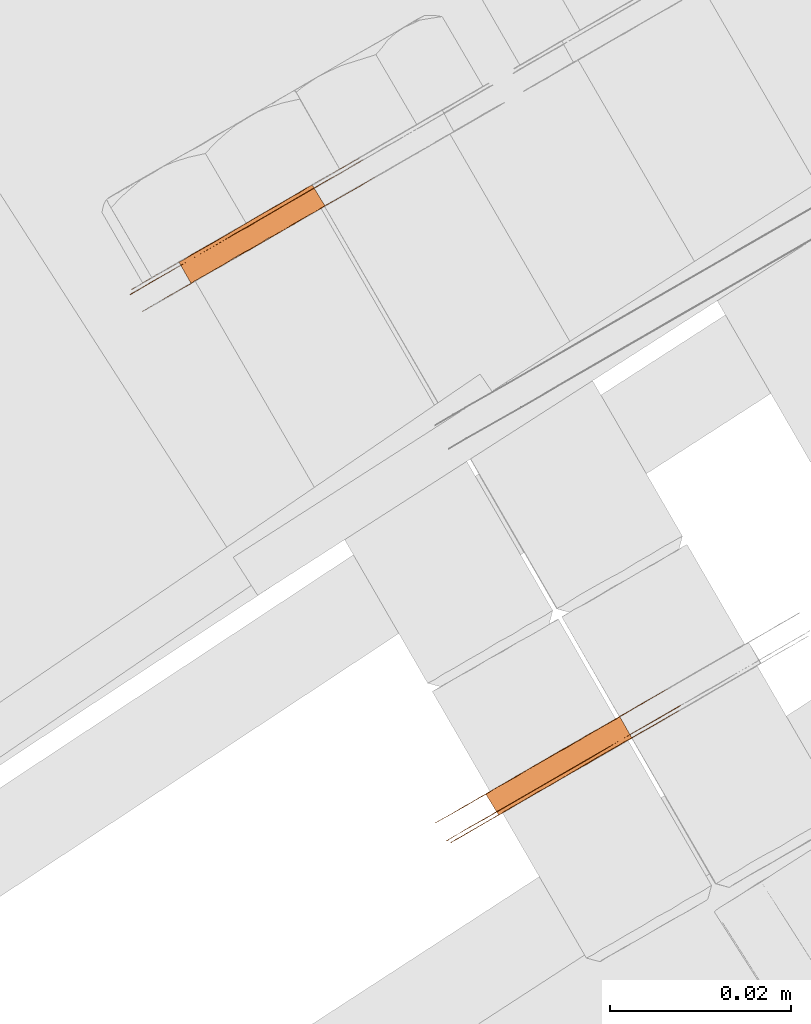
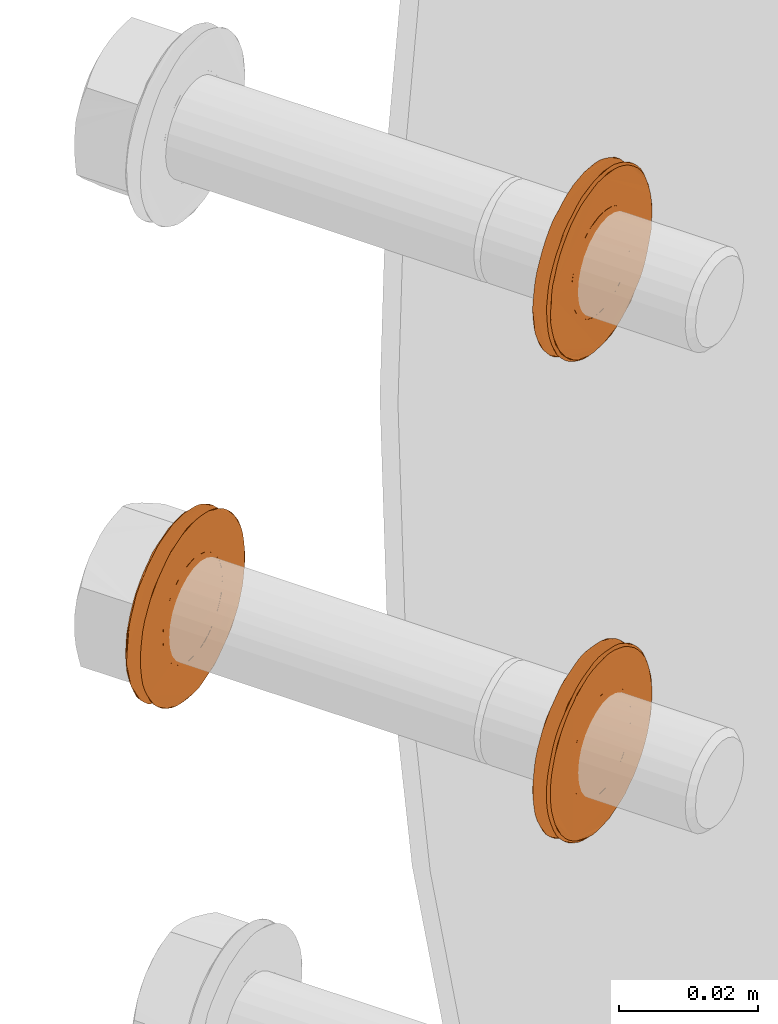
# One storey, part 104 of 126: 3 proxies.
"""IFC2X3 building model written with IfcOpenShell, lengths in millimetres."""

from ifc_helpers import new_model, si_unit, origin, origin_with_axes, place, context, project, spatial, faceted_brep, material, element, save


model = new_model("IFC2X3")

# Units and contexts
context_of_model_1 = context(None, 3, precision=0.1, world=origin())
context_of_model_2 = context(None, 3, precision=0.1, world=origin())
ifc_project = project(units=[si_unit("LENGTHUNIT", "METRE", prefix="MILLI"), si_unit("AREAUNIT", "SQUARE_METRE", prefix="CENTI"), si_unit("VOLUMEUNIT", "CUBIC_METRE", prefix="CENTI"), si_unit("MASSUNIT", "GRAM", prefix="KILO")], contexts=[context_of_model_1, context_of_model_2])

# Site, building, storey
site_placement = place(None, origin_with_axes())
site = spatial("IfcSite", under=ifc_project, at=site_placement, CompositionType="ELEMENT")
building_placement = place(site_placement, origin_with_axes())
building = spatial("IfcBuilding", under=site, at=building_placement, CompositionType="ELEMENT")
storey_placement = place(building_placement, origin_with_axes())
storey = spatial("IfcBuildingStorey", under=building, at=storey_placement, CompositionType="ELEMENT")

# Proxies
ifc_material = material(Name="STAHL")
proxy_1_placement = place(storey_placement, origin_with_axes())
element("IfcBuildingElementProxy", 1, at=proxy_1_placement, inside=storey, material=ifc_material, Name="profile", context=context_of_model_2, shape_type="Brep", body=[
    faceted_brep([(3655.9, 14697.4, 850.3), (3654.6, 14699.7, 850.3), (3654.1, 14699.4, 849.3), (3655.4, 14697.1, 849.3), (3656.3, 14697.6, 851.5), (3655.0, 14699.9, 851.5), (3656.5, 14697.7, 852.6), (3655.2, 14700.1, 852.6), (3656.6, 14697.8, 853.9), (3655.3, 14700.1, 853.9), (3642.0, 14689.3, 852.6), (3640.6, 14691.6, 852.6), (3640.5, 14691.6, 853.9), (3641.9, 14689.3, 853.9), (3642.2, 14689.4, 851.5), (3640.8, 14691.8, 851.5), (3642.6, 14689.7, 850.3), (3641.2, 14692.0, 850.3), (3643.1, 14689.9, 849.3), (3641.7, 14692.3, 849.3), (3643.7, 14690.3, 848.3), (3642.3, 14692.6, 848.3), (3644.4, 14690.7, 847.4), (3643.1, 14693.1, 847.4), (3645.3, 14691.2, 846.7), (3643.9, 14693.6, 846.7), (3646.2, 14691.8, 846.1), (3644.8, 14694.1, 846.1), (3647.2, 14692.3, 845.7), (3645.8, 14694.7, 845.7), (3648.2, 14692.9, 845.4), (3646.9, 14695.3, 845.4), (3649.3, 14693.5, 845.4), (3647.9, 14695.9, 845.4), (3650.3, 14694.1, 845.4), (3648.9, 14696.5, 845.4), (3651.3, 14694.7, 845.7), (3650.0, 14697.1, 845.7), (3652.3, 14695.3, 846.1), (3651.0, 14697.6, 846.1), (3653.2, 14695.8, 846.7), (3651.9, 14698.2, 846.7), (3654.1, 14696.3, 847.4), (3652.7, 14698.6, 847.4), (3654.8, 14696.7, 848.3), (3653.5, 14699.1, 848.3), (3636.1, 14686.4, 853.9), (3636.1, 14686.4, 855.4), (3636.3, 14686.5, 857.0), (3636.7, 14686.7, 858.5), (3637.2, 14687.0, 860.0), (3637.8, 14687.4, 861.4), (3638.5, 14687.8, 862.7), (3639.4, 14688.3, 863.9), (3640.4, 14688.8, 865.0), (3641.4, 14689.5, 866.0), (3642.6, 14690.1, 866.8), (3643.8, 14690.8, 867.6), (3645.0, 14691.5, 868.1), (3646.4, 14692.3, 868.5), (3647.7, 14693.1, 868.8), (3649.1, 14693.9, 868.9), (3650.4, 14694.6, 868.8), (3651.8, 14695.4, 868.5), (3653.1, 14696.2, 868.1), (3654.3, 14696.9, 867.6), (3655.5, 14697.6, 866.8), (3656.7, 14698.3, 866.0), (3657.7, 14698.9, 865.0), (3658.7, 14699.4, 863.9), (3659.6, 14699.9, 862.7), (3660.3, 14700.4, 861.4), (3660.9, 14700.7, 860.0), (3661.4, 14701.0, 858.5), (3661.8, 14701.2, 857.0), (3662.0, 14701.3, 855.4), (3662.0, 14701.4, 853.9), (3662.0, 14701.3, 852.3), (3661.8, 14701.2, 850.7), (3661.4, 14701.0, 849.2), (3660.9, 14700.7, 847.8), (3660.3, 14700.4, 846.4), (3659.6, 14699.9, 845.0), (3658.7, 14699.4, 843.8), (3657.7, 14698.9, 842.7), (3656.7, 14698.3, 841.7), (3655.5, 14700.3, 841.7), (3656.6, 14700.9, 842.7), (3657.6, 14701.4, 843.8), (3658.4, 14701.9, 845.0), (3659.2, 14702.4, 846.4), (3659.8, 14702.7, 847.8), (3660.3, 14703.0, 849.2), (3660.6, 14703.2, 850.7), (3660.8, 14703.3, 852.3), (3660.9, 14703.4, 853.9), (3660.8, 14703.3, 855.4), (3660.6, 14703.2, 857.0), (3660.3, 14703.0, 858.5), (3659.8, 14702.7, 860.0), (3659.2, 14702.4, 861.4), (3658.4, 14701.9, 862.7), (3657.6, 14701.4, 863.9), (3656.6, 14700.9, 865.0), (3655.5, 14700.3, 866.0), (3654.4, 14699.6, 866.8), (3653.2, 14698.9, 867.6), (3651.9, 14698.2, 868.1), (3650.6, 14697.4, 868.5), (3649.3, 14696.6, 868.8), (3647.9, 14695.9, 868.9), (3646.5, 14695.1, 868.8), (3645.2, 14694.3, 868.5), (3643.9, 14693.5, 868.1), (3642.6, 14692.8, 867.6), (3641.4, 14692.1, 866.8), (3640.3, 14691.4, 866.0), (3639.2, 14690.8, 865.0), (3638.2, 14690.3, 863.9), (3637.4, 14689.8, 862.7), (3636.7, 14689.4, 861.4), (3636.0, 14689.0, 860.0), (3635.5, 14688.7, 858.5), (3635.2, 14688.5, 857.0), (3635.0, 14688.4, 855.4), (3634.9, 14688.4, 853.9), (3635.0, 14688.4, 852.3), (3635.2, 14688.5, 850.7), (3635.5, 14688.7, 849.2), (3636.0, 14689.0, 847.8), (3636.7, 14689.4, 846.4), (3637.4, 14689.8, 845.0), (3638.2, 14690.3, 843.8), (3639.2, 14690.8, 842.7), (3640.3, 14691.4, 841.7), (3641.4, 14692.1, 840.9), (3642.6, 14692.8, 840.1), (3643.9, 14693.5, 839.6), (3645.2, 14694.3, 839.2), (3646.5, 14695.1, 838.9), (3647.9, 14695.9, 838.9), (3649.3, 14696.6, 838.9), (3650.6, 14697.4, 839.2), (3651.9, 14698.2, 839.6), (3653.2, 14698.9, 840.1), (3654.4, 14699.6, 840.9), (3655.5, 14697.6, 840.9), (3654.3, 14696.9, 840.1), (3653.1, 14696.2, 839.6), (3651.8, 14695.4, 839.2), (3650.4, 14694.6, 838.9), (3649.1, 14693.9, 838.9), (3647.7, 14693.1, 838.9), (3646.4, 14692.3, 839.2), (3645.0, 14691.5, 839.6), (3643.8, 14690.8, 840.1), (3642.6, 14690.1, 840.9), (3641.4, 14689.5, 841.7), (3640.4, 14688.8, 842.7), (3639.4, 14688.3, 843.8), (3638.5, 14687.8, 845.0), (3637.8, 14687.4, 846.4), (3637.2, 14687.0, 847.8), (3636.7, 14686.7, 849.2), (3636.3, 14686.5, 850.7), (3636.1, 14686.4, 852.3), (3636.6, 14686.2, 853.9), (3636.7, 14686.3, 855.4), (3636.9, 14686.4, 857.0), (3637.3, 14686.6, 858.5), (3637.8, 14686.9, 860.0), (3638.4, 14687.3, 861.4), (3639.2, 14687.7, 862.7), (3640.1, 14688.2, 863.9), (3641.1, 14688.8, 865.0), (3642.2, 14689.4, 865.9), (3643.3, 14690.1, 866.8), (3644.6, 14690.8, 867.4), (3645.9, 14691.6, 867.9), (3647.2, 14692.3, 868.3), (3648.6, 14693.1, 868.4), (3649.9, 14693.9, 868.4), (3651.3, 14694.7, 868.3), (3652.6, 14695.5, 867.9), (3653.9, 14696.2, 867.4), (3655.2, 14696.9, 866.8), (3656.3, 14697.6, 865.9), (3657.4, 14698.2, 865.0), (3658.4, 14698.8, 863.9), (3659.3, 14699.3, 862.7), (3660.1, 14699.8, 861.4), (3660.7, 14700.1, 860.0), (3661.2, 14700.4, 858.5), (3661.6, 14700.6, 857.0), (3661.8, 14700.8, 855.4), (3661.9, 14700.8, 853.9), (3661.8, 14700.8, 852.3), (3661.6, 14700.6, 850.7), (3661.2, 14700.4, 849.2), (3660.7, 14700.1, 847.7), (3660.1, 14699.8, 846.3), (3659.3, 14699.3, 845.0), (3658.4, 14698.8, 843.8), (3657.4, 14698.2, 842.7), (3656.3, 14697.6, 841.8), (3655.2, 14696.9, 841.0), (3653.9, 14696.2, 840.3), (3652.6, 14695.5, 839.8), (3651.3, 14694.7, 839.4), (3649.9, 14693.9, 839.3), (3648.6, 14693.1, 839.3), (3647.2, 14692.3, 839.4), (3645.9, 14691.6, 839.8), (3644.6, 14690.8, 840.3), (3643.3, 14690.1, 841.0), (3642.2, 14689.4, 841.8), (3641.1, 14688.8, 842.7), (3640.1, 14688.2, 843.8), (3639.2, 14687.7, 845.0), (3638.4, 14687.3, 846.3), (3637.8, 14686.9, 847.7), (3637.3, 14686.6, 849.2), (3636.9, 14686.4, 850.7), (3636.7, 14686.3, 852.3), (3654.8, 14696.7, 859.4), (3655.4, 14697.1, 858.4), (3655.9, 14697.4, 857.4), (3656.3, 14697.6, 856.2), (3656.5, 14697.7, 855.1), (3642.0, 14689.3, 855.1), (3642.2, 14689.4, 856.2), (3642.6, 14689.7, 857.4), (3643.1, 14689.9, 858.4), (3643.7, 14690.3, 859.4), (3644.4, 14690.7, 860.3), (3645.3, 14691.2, 861.0), (3646.2, 14691.8, 861.6), (3647.2, 14692.3, 862.0), (3648.2, 14692.9, 862.3), (3649.3, 14693.5, 862.4), (3650.3, 14694.1, 862.3), (3651.3, 14694.7, 862.0), (3652.3, 14695.3, 861.6), (3653.2, 14695.8, 861.0), (3654.1, 14696.3, 860.3), (3640.6, 14691.6, 855.1), (3655.2, 14700.1, 855.1), (3655.0, 14699.9, 856.2), (3654.6, 14699.7, 857.4), (3654.1, 14699.4, 858.4), (3653.5, 14699.1, 859.4), (3652.7, 14698.6, 860.3), (3651.9, 14698.2, 861.0), (3651.0, 14697.6, 861.6), (3650.0, 14697.1, 862.0), (3648.9, 14696.5, 862.3), (3647.9, 14695.9, 862.4), (3646.9, 14695.3, 862.3), (3645.8, 14694.7, 862.0), (3644.8, 14694.1, 861.6), (3643.9, 14693.6, 861.0), (3643.1, 14693.1, 860.3), (3642.3, 14692.6, 859.4), (3641.7, 14692.3, 858.4), (3641.2, 14692.0, 857.4), (3640.8, 14691.8, 856.2)], [[[0, 1, 2, 3]], [[4, 5, 1, 0]], [[6, 7, 5, 4]], [[6, 8, 9, 7]], [[10, 11, 12, 13]], [[14, 15, 11, 10]], [[16, 17, 15, 14]], [[18, 19, 17, 16]], [[20, 21, 19, 18]], [[22, 23, 21, 20]], [[24, 25, 23, 22]], [[26, 27, 25, 24]], [[28, 29, 27, 26]], [[30, 31, 29, 28]], [[32, 33, 31, 30]], [[34, 35, 33, 32]], [[36, 37, 35, 34]], [[38, 39, 37, 36]], [[40, 41, 39, 38]], [[42, 43, 41, 40]], [[44, 45, 43, 42]], [[3, 2, 45, 44]], [[46, 47, 48, 49, 50, 51, 52, 53, 54, 55, 56, 57, 58, 59, 60, 61, 62, 63, 64, 65, 66, 67, 68, 69, 70, 71, 72, 73, 74, 75, 76, 77, 78, 79, 80, 81, 82, 83, 84, 85, 86, 87, 88, 89, 90, 91, 92, 93, 94, 95, 96, 97, 98, 99, 100, 101, 102, 103, 104, 105, 106, 107, 108, 109, 110, 111, 112, 113, 114, 115, 116, 117, 118, 119, 120, 121, 122, 123, 124, 125, 126, 127, 128, 129, 130, 131, 132, 133, 134, 135, 136, 137, 138, 139, 140, 141, 142, 143, 144, 145, 86, 85, 146, 147, 148, 149, 150, 151, 152, 153, 154, 155, 156, 157, 158, 159, 160, 161, 162, 163, 164, 165]], [[166, 167, 168, 169, 170, 171, 172, 173, 174, 175, 176, 177, 178, 179, 180, 181, 182, 183, 184, 185, 186, 187, 68, 67, 66, 65, 64, 63, 62, 61, 60, 59, 58, 57, 56, 55, 54, 53, 52, 51, 50, 49, 48, 47, 46, 165, 164, 163, 162, 161, 160, 159, 158, 157, 156, 155, 154, 153, 152, 151, 150, 149, 148, 147, 146, 85, 84, 83, 82, 81, 80, 79, 78, 77, 76, 75, 74, 73, 72, 71, 70, 69, 68, 187, 188, 189, 190, 191, 192, 193, 194, 195, 196, 197, 198, 199, 200, 201, 202, 203, 204, 205, 206, 207, 208, 209, 210, 211, 212, 213, 214, 215, 216, 217, 218, 219, 220, 221, 222, 223]], [[166, 223, 222, 221, 220, 219, 218, 217, 216, 215, 214, 213, 212, 211, 210, 209, 208, 207, 206, 205, 204, 203, 202, 201, 200, 199, 198, 197, 196, 195, 194, 193, 192, 191, 190, 189, 188, 224, 225, 226, 227, 228, 8, 6, 4, 0, 3, 44, 42, 40, 38, 36, 34, 32, 30, 28, 26, 24, 22, 20, 18, 16, 14, 10, 13, 229, 230, 231, 232, 233, 234, 235, 236, 237, 238, 239, 240, 241, 242, 243, 244, 224, 188, 187, 186, 185, 184, 183, 182, 181, 180, 179, 178, 177, 176, 175, 174, 173, 172, 171, 170, 169, 168, 167]], [[229, 13, 12, 245]], [[228, 246, 9, 8]], [[228, 227, 247, 246]], [[227, 226, 248, 247]], [[226, 225, 249, 248]], [[225, 224, 250, 249]], [[224, 244, 251, 250]], [[244, 243, 252, 251]], [[243, 242, 253, 252]], [[242, 241, 254, 253]], [[241, 240, 255, 254]], [[240, 239, 256, 255]], [[239, 238, 257, 256]], [[238, 237, 258, 257]], [[237, 236, 259, 258]], [[236, 235, 260, 259]], [[235, 234, 261, 260]], [[234, 233, 262, 261]], [[233, 232, 263, 262]], [[232, 231, 264, 263]], [[231, 230, 265, 264]], [[230, 229, 245, 265]], [[125, 124, 123, 122, 121, 120, 119, 118, 117, 116, 115, 114, 113, 112, 111, 110, 109, 108, 107, 106, 105, 104, 103, 102, 101, 250, 251, 252, 253, 254, 255, 256, 257, 258, 259, 260, 261, 262, 263, 264, 265, 245, 12, 11, 15, 17, 19, 21, 23, 25, 27, 29, 31, 33, 35, 37, 39, 41, 43, 45, 2, 1, 5, 7, 9, 246, 247, 248, 249, 250, 101, 100, 99, 98, 97, 96, 95, 94, 93, 92, 91, 90, 89, 88, 87, 86, 145, 144, 143, 142, 141, 140, 139, 138, 137, 136, 135, 134, 133, 132, 131, 130, 129, 128, 127, 126]]]),
])
proxy_2_placement = place(storey_placement, origin_with_axes())
element("IfcBuildingElementProxy", 2, at=proxy_2_placement, inside=storey, material=ifc_material, Name="profile", context=context_of_model_2, shape_type="Brep", body=[
    faceted_brep([(3621.4, 14758.7, 853.9), (3622.8, 14756.4, 853.9), (3622.7, 14756.4, 855.1), (3621.3, 14758.7, 855.1), (3606.7, 14750.2, 853.9), (3606.8, 14750.3, 855.1), (3608.1, 14747.9, 855.1), (3608.0, 14747.9, 853.9), (3607.0, 14750.4, 856.2), (3608.3, 14748.1, 856.2), (3607.4, 14750.6, 857.4), (3608.7, 14748.3, 857.4), (3607.9, 14750.9, 858.4), (3609.2, 14748.6, 858.4), (3608.5, 14751.3, 859.4), (3609.8, 14748.9, 859.4), (3609.2, 14751.7, 860.3), (3610.6, 14749.4, 860.3), (3610.1, 14752.2, 861.0), (3611.4, 14749.8, 861.0), (3611.0, 14752.7, 861.6), (3612.3, 14750.4, 861.6), (3612.0, 14753.3, 862.0), (3613.3, 14751.0, 862.0), (3613.0, 14753.9, 862.3), (3614.4, 14751.5, 862.3), (3614.1, 14754.5, 862.4), (3615.4, 14752.1, 862.4), (3615.1, 14755.1, 862.3), (3616.4, 14752.8, 862.3), (3616.1, 14755.7, 862.0), (3617.5, 14753.3, 862.0), (3617.1, 14756.3, 861.6), (3618.5, 14753.9, 861.6), (3618.0, 14756.8, 861.0), (3619.4, 14754.4, 861.0), (3618.9, 14757.3, 860.3), (3620.2, 14754.9, 860.3), (3619.6, 14757.7, 859.4), (3621.0, 14755.4, 859.4), (3620.2, 14758.1, 858.4), (3621.6, 14755.7, 858.4), (3620.7, 14758.4, 857.4), (3622.1, 14756.0, 857.4), (3621.1, 14758.6, 856.2), (3622.5, 14756.2, 856.2), (3602.4, 14744.6, 853.9), (3602.5, 14744.7, 855.4), (3602.7, 14744.8, 857.0), (3603.0, 14745.0, 858.5), (3603.5, 14745.3, 860.0), (3604.2, 14745.7, 861.4), (3604.9, 14746.1, 862.7), (3605.7, 14746.6, 863.9), (3606.7, 14747.1, 865.0), (3607.8, 14747.7, 866.0), (3608.9, 14748.4, 866.8), (3610.1, 14749.1, 867.6), (3611.4, 14749.8, 868.1), (3612.7, 14750.6, 868.5), (3614.0, 14751.4, 868.8), (3615.4, 14752.1, 868.9), (3616.8, 14752.9, 868.8), (3618.1, 14753.7, 868.5), (3619.4, 14754.5, 868.1), (3620.7, 14755.2, 867.6), (3620.7, 14757.9, 866.8), (3619.5, 14757.2, 867.6), (3618.3, 14756.5, 868.1), (3617.0, 14755.7, 868.5), (3615.6, 14754.9, 868.8), (3614.3, 14754.1, 868.9), (3612.9, 14753.4, 868.8), (3611.6, 14752.6, 868.5), (3610.2, 14751.8, 868.1), (3609.0, 14751.1, 867.6), (3607.8, 14750.4, 866.8), (3606.6, 14749.7, 866.0), (3605.6, 14749.1, 865.0), (3604.6, 14748.6, 863.9), (3603.7, 14748.1, 862.7), (3603.0, 14747.6, 861.4), (3602.4, 14747.3, 860.0), (3601.9, 14747.0, 858.5), (3601.5, 14746.8, 857.0), (3601.3, 14746.7, 855.4), (3601.3, 14746.6, 853.9), (3601.3, 14746.7, 852.3), (3601.5, 14746.8, 850.7), (3601.9, 14747.0, 849.2), (3602.4, 14747.3, 847.8), (3603.0, 14747.6, 846.4), (3603.7, 14748.1, 845.0), (3604.6, 14748.6, 843.8), (3605.6, 14749.1, 842.7), (3606.6, 14749.7, 841.7), (3607.8, 14750.4, 840.9), (3609.0, 14751.1, 840.1), (3610.2, 14751.8, 839.6), (3611.6, 14752.6, 839.2), (3612.9, 14753.4, 838.9), (3614.3, 14754.1, 838.9), (3615.6, 14754.9, 838.9), (3617.0, 14755.7, 839.2), (3618.3, 14756.5, 839.6), (3619.5, 14757.2, 840.1), (3620.7, 14757.9, 840.9), (3621.9, 14758.5, 841.7), (3622.9, 14759.2, 842.7), (3623.9, 14759.7, 843.8), (3624.8, 14760.2, 845.0), (3625.5, 14760.6, 846.4), (3626.1, 14761.0, 847.8), (3626.6, 14761.3, 849.2), (3627.0, 14761.5, 850.7), (3627.2, 14761.6, 852.3), (3627.2, 14761.6, 853.9), (3627.2, 14761.6, 855.4), (3627.0, 14761.5, 857.0), (3626.6, 14761.3, 858.5), (3626.1, 14761.0, 860.0), (3625.5, 14760.6, 861.4), (3624.8, 14760.2, 862.7), (3623.9, 14759.7, 863.9), (3622.9, 14759.2, 865.0), (3621.9, 14758.5, 866.0), (3621.9, 14755.9, 866.8), (3623.0, 14756.6, 866.0), (3624.1, 14757.2, 865.0), (3625.1, 14757.7, 863.9), (3625.9, 14758.2, 862.7), (3626.7, 14758.6, 861.4), (3627.3, 14759.0, 860.0), (3627.8, 14759.3, 858.5), (3628.1, 14759.5, 857.0), (3628.3, 14759.6, 855.4), (3628.4, 14759.6, 853.9), (3628.3, 14759.6, 852.3), (3628.1, 14759.5, 850.7), (3627.8, 14759.3, 849.2), (3627.3, 14759.0, 847.8), (3626.7, 14758.6, 846.4), (3625.9, 14758.2, 845.0), (3625.1, 14757.7, 843.8), (3624.1, 14757.2, 842.7), (3623.0, 14756.6, 841.7), (3621.9, 14755.9, 840.9), (3620.7, 14755.2, 840.1), (3619.4, 14754.5, 839.6), (3618.1, 14753.7, 839.2), (3616.8, 14752.9, 838.9), (3615.4, 14752.1, 838.9), (3614.0, 14751.4, 838.9), (3612.7, 14750.6, 839.2), (3611.4, 14749.8, 839.6), (3610.1, 14749.1, 840.1), (3608.9, 14748.4, 840.9), (3607.8, 14747.7, 841.7), (3606.7, 14747.1, 842.7), (3605.7, 14746.6, 843.8), (3604.9, 14746.1, 845.0), (3604.2, 14745.7, 846.4), (3603.5, 14745.3, 847.8), (3603.0, 14745.0, 849.2), (3602.7, 14744.8, 850.7), (3602.5, 14744.7, 852.3), (3623.2, 14759.8, 843.8), (3624.1, 14760.3, 845.0), (3624.9, 14760.7, 846.3), (3625.5, 14761.1, 847.7), (3626.0, 14761.4, 849.2), (3626.4, 14761.6, 850.7), (3626.6, 14761.7, 852.3), (3626.7, 14761.8, 853.9), (3626.6, 14761.7, 855.4), (3626.4, 14761.6, 857.0), (3626.0, 14761.4, 858.5), (3625.5, 14761.1, 860.0), (3624.9, 14760.7, 861.4), (3624.1, 14760.3, 862.7), (3623.2, 14759.8, 863.9), (3622.2, 14759.2, 865.0), (3621.1, 14758.6, 865.9), (3620.0, 14757.9, 866.8), (3618.7, 14757.2, 867.4), (3617.4, 14756.4, 867.9), (3616.1, 14755.7, 868.3), (3614.7, 14754.9, 868.4), (3613.4, 14754.1, 868.4), (3612.0, 14753.3, 868.3), (3610.7, 14752.5, 867.9), (3609.4, 14751.8, 867.4), (3608.1, 14751.1, 866.8), (3607.0, 14750.4, 865.9), (3605.9, 14749.8, 865.0), (3604.9, 14749.2, 863.9), (3604.0, 14748.7, 862.7), (3603.2, 14748.2, 861.4), (3602.6, 14747.9, 860.0), (3602.1, 14747.6, 858.5), (3601.7, 14747.4, 857.0), (3601.5, 14747.2, 855.4), (3601.4, 14747.2, 853.9), (3601.5, 14747.2, 852.3), (3601.7, 14747.4, 850.7), (3602.1, 14747.6, 849.2), (3602.6, 14747.9, 847.7), (3603.2, 14748.2, 846.3), (3604.0, 14748.7, 845.0), (3604.9, 14749.2, 843.8), (3605.9, 14749.8, 842.7), (3607.0, 14750.4, 841.8), (3608.1, 14751.1, 841.0), (3609.4, 14751.8, 840.3), (3610.7, 14752.5, 839.8), (3612.0, 14753.3, 839.4), (3613.4, 14754.1, 839.3), (3614.7, 14754.9, 839.3), (3616.1, 14755.7, 839.4), (3617.4, 14756.4, 839.8), (3618.7, 14757.2, 840.3), (3620.0, 14757.9, 841.0), (3621.1, 14758.6, 841.8), (3622.2, 14759.2, 842.7), (3619.6, 14757.7, 848.3), (3620.2, 14758.1, 849.3), (3620.7, 14758.4, 850.3), (3621.1, 14758.6, 851.5), (3621.3, 14758.7, 852.6), (3606.8, 14750.3, 852.6), (3607.0, 14750.4, 851.5), (3607.4, 14750.6, 850.3), (3607.9, 14750.9, 849.3), (3608.5, 14751.3, 848.3), (3609.2, 14751.7, 847.4), (3610.1, 14752.2, 846.7), (3611.0, 14752.7, 846.1), (3612.0, 14753.3, 845.7), (3613.0, 14753.9, 845.4), (3614.1, 14754.5, 845.4), (3615.1, 14755.1, 845.4), (3616.1, 14755.7, 845.7), (3617.1, 14756.3, 846.1), (3618.0, 14756.8, 846.7), (3618.9, 14757.3, 847.4), (3608.7, 14748.3, 850.3), (3609.2, 14748.6, 849.3), (3608.3, 14748.1, 851.5), (3622.7, 14756.4, 852.6), (3608.1, 14747.9, 852.6), (3622.5, 14756.2, 851.5), (3622.1, 14756.0, 850.3), (3621.6, 14755.7, 849.3), (3621.0, 14755.4, 848.3), (3620.2, 14754.9, 847.4), (3619.4, 14754.4, 846.7), (3618.5, 14753.9, 846.1), (3617.5, 14753.3, 845.7), (3616.4, 14752.8, 845.4), (3615.4, 14752.1, 845.4), (3614.4, 14751.5, 845.4), (3613.3, 14751.0, 845.7), (3612.3, 14750.4, 846.1), (3611.4, 14749.8, 846.7), (3610.6, 14749.4, 847.4), (3609.8, 14748.9, 848.3)], [[[0, 1, 2, 3]], [[4, 5, 6, 7]], [[5, 8, 9, 6]], [[8, 10, 11, 9]], [[10, 12, 13, 11]], [[12, 14, 15, 13]], [[14, 16, 17, 15]], [[16, 18, 19, 17]], [[18, 20, 21, 19]], [[20, 22, 23, 21]], [[22, 24, 25, 23]], [[24, 26, 27, 25]], [[26, 28, 29, 27]], [[28, 30, 31, 29]], [[30, 32, 33, 31]], [[32, 34, 35, 33]], [[34, 36, 37, 35]], [[36, 38, 39, 37]], [[38, 40, 41, 39]], [[40, 42, 43, 41]], [[42, 44, 45, 43]], [[44, 3, 2, 45]], [[46, 47, 48, 49, 50, 51, 52, 53, 54, 55, 56, 57, 58, 59, 60, 61, 62, 63, 64, 65, 66, 67, 68, 69, 70, 71, 72, 73, 74, 75, 76, 77, 78, 79, 80, 81, 82, 83, 84, 85, 86, 87, 88, 89, 90, 91, 92, 93, 94, 95, 96, 97, 98, 99, 100, 101, 102, 103, 104, 105, 106, 107, 108, 109, 110, 111, 112, 113, 114, 115, 116, 117, 118, 119, 120, 121, 122, 123, 124, 125, 66, 65, 126, 127, 128, 129, 130, 131, 132, 133, 134, 135, 136, 137, 138, 139, 140, 141, 142, 143, 144, 145, 146, 147, 148, 149, 150, 151, 152, 153, 154, 155, 156, 157, 158, 159, 160, 161, 162, 163, 164, 165]], [[86, 85, 84, 83, 82, 81, 80, 79, 78, 77, 76, 75, 74, 73, 72, 71, 70, 69, 68, 67, 66, 125, 124, 123, 122, 121, 120, 119, 118, 117, 116, 115, 114, 113, 112, 111, 110, 109, 166, 167, 168, 169, 170, 171, 172, 173, 174, 175, 176, 177, 178, 179, 180, 181, 182, 183, 184, 185, 186, 187, 188, 189, 190, 191, 192, 193, 194, 195, 196, 197, 198, 199, 200, 201, 202, 203, 204, 205, 206, 207, 208, 209, 210, 211, 212, 213, 214, 215, 216, 217, 218, 219, 220, 221, 222, 223, 166, 109, 108, 107, 106, 105, 104, 103, 102, 101, 100, 99, 98, 97, 96, 95, 94, 93, 92, 91, 90, 89, 88, 87]], [[202, 201, 200, 199, 198, 197, 196, 195, 194, 193, 192, 191, 190, 189, 188, 187, 186, 185, 184, 183, 182, 181, 180, 179, 178, 177, 176, 175, 174, 173, 172, 171, 170, 169, 168, 167, 166, 224, 225, 226, 227, 228, 0, 3, 44, 42, 40, 38, 36, 34, 32, 30, 28, 26, 24, 22, 20, 18, 16, 14, 12, 10, 8, 5, 4, 229, 230, 231, 232, 233, 234, 235, 236, 237, 238, 239, 240, 241, 242, 243, 244, 224, 166, 223, 222, 221, 220, 219, 218, 217, 216, 215, 214, 213, 212, 211, 210, 209, 208, 207, 206, 205, 204, 203]], [[231, 245, 246, 232]], [[230, 247, 245, 231]], [[0, 228, 248, 1]], [[229, 249, 247, 230]], [[4, 7, 249, 229]], [[227, 250, 248, 228]], [[226, 251, 250, 227]], [[225, 252, 251, 226]], [[224, 253, 252, 225]], [[244, 254, 253, 224]], [[243, 255, 254, 244]], [[242, 256, 255, 243]], [[241, 257, 256, 242]], [[240, 258, 257, 241]], [[239, 259, 258, 240]], [[238, 260, 259, 239]], [[237, 261, 260, 238]], [[236, 262, 261, 237]], [[235, 263, 262, 236]], [[234, 264, 263, 235]], [[233, 265, 264, 234]], [[232, 246, 265, 233]], [[46, 165, 164, 163, 162, 161, 160, 159, 158, 157, 156, 155, 154, 153, 152, 151, 150, 149, 148, 147, 146, 145, 144, 143, 142, 253, 254, 255, 256, 257, 258, 259, 260, 261, 262, 263, 264, 265, 246, 245, 247, 249, 7, 6, 9, 11, 13, 15, 17, 19, 21, 23, 25, 27, 29, 31, 33, 35, 37, 39, 41, 43, 45, 2, 1, 248, 250, 251, 252, 253, 142, 141, 140, 139, 138, 137, 136, 135, 134, 133, 132, 131, 130, 129, 128, 127, 126, 65, 64, 63, 62, 61, 60, 59, 58, 57, 56, 55, 54, 53, 52, 51, 50, 49, 48, 47]]]),
])
proxy_3_placement = place(storey_placement, origin_with_axes())
element("IfcBuildingElementProxy", 3, at=proxy_3_placement, inside=storey, material=ifc_material, Name="profile", context=context_of_model_2, shape_type="Brep", body=[
    faceted_brep([(3655.2, 14697.0, 933.2), (3653.9, 14699.3, 933.2), (3653.2, 14698.9, 932.2), (3654.5, 14696.6, 932.2), (3655.8, 14697.3, 934.2), (3654.4, 14699.6, 934.2), (3656.2, 14697.5, 935.3), (3654.8, 14699.9, 935.3), (3641.9, 14689.3, 938.6), (3640.6, 14691.6, 938.6), (3640.7, 14691.7, 939.8), (3642.0, 14689.3, 939.8), (3656.5, 14697.7, 936.5), (3655.1, 14700.0, 936.5), (3641.9, 14689.3, 937.4), (3640.6, 14691.6, 937.4), (3642.1, 14689.4, 936.2), (3640.7, 14691.7, 936.2), (3642.4, 14689.6, 935.0), (3641.1, 14691.9, 935.0), (3642.9, 14689.8, 933.9), (3641.5, 14692.2, 933.9), (3643.4, 14690.2, 932.9), (3642.1, 14692.5, 932.9), (3644.1, 14690.6, 932.0), (3642.8, 14692.9, 932.0), (3644.9, 14691.0, 931.3), (3643.6, 14693.4, 931.3), (3645.8, 14691.5, 930.6), (3644.5, 14693.9, 930.6), (3646.8, 14692.1, 930.1), (3645.5, 14694.4, 930.1), (3647.8, 14692.7, 929.8), (3646.5, 14695.0, 929.8), (3648.9, 14693.3, 929.7), (3647.5, 14695.6, 929.7), (3649.9, 14693.9, 929.7), (3648.6, 14696.2, 929.7), (3650.9, 14694.5, 929.9), (3649.6, 14696.8, 929.9), (3651.9, 14695.1, 930.2), (3650.6, 14697.4, 930.2), (3652.9, 14695.6, 930.8), (3651.5, 14698.0, 930.8), (3653.8, 14696.1, 931.4), (3652.4, 14698.5, 931.4), (3636.1, 14686.4, 938.0), (3636.1, 14686.4, 939.5), (3636.3, 14686.5, 941.1), (3636.6, 14686.7, 942.6), (3637.1, 14687.0, 944.1), (3637.7, 14687.3, 945.5), (3638.4, 14687.7, 946.8), (3639.3, 14688.2, 948.0), (3640.2, 14688.8, 949.2), (3641.3, 14689.4, 950.2), (3642.4, 14690.0, 951.0), (3643.6, 14690.7, 951.8), (3644.9, 14691.5, 952.4), (3646.2, 14692.2, 952.8), (3647.5, 14693.0, 953.0), (3648.9, 14693.8, 953.1), (3650.2, 14694.6, 953.1), (3651.6, 14695.3, 952.9), (3652.9, 14696.1, 952.5), (3654.2, 14696.8, 951.9), (3655.4, 14697.5, 951.2), (3656.5, 14698.2, 950.4), (3657.6, 14698.8, 949.4), (3658.6, 14699.4, 948.3), (3659.5, 14699.9, 947.1), (3660.2, 14700.3, 945.8), (3660.8, 14700.7, 944.4), (3661.4, 14701.0, 943.0), (3661.7, 14701.2, 941.5), (3662.0, 14701.3, 939.9), (3662.0, 14701.4, 938.3), (3662.0, 14701.3, 936.8), (3661.8, 14701.2, 935.2), (3661.5, 14701.0, 933.7), (3661.0, 14700.8, 932.2), (3660.4, 14700.4, 930.8), (3659.7, 14700.0, 929.5), (3658.8, 14699.5, 928.3), (3657.9, 14699.0, 927.1), (3656.8, 14698.4, 926.1), (3655.7, 14697.7, 925.3), (3654.5, 14697.0, 924.5), (3653.3, 14699.0, 924.5), (3654.5, 14699.7, 925.3), (3655.7, 14700.3, 926.1), (3656.7, 14700.9, 927.1), (3657.7, 14701.5, 928.3), (3658.5, 14702.0, 929.5), (3659.2, 14702.4, 930.8), (3659.8, 14702.7, 932.2), (3660.3, 14703.0, 933.7), (3660.6, 14703.2, 935.2), (3660.8, 14703.3, 936.8), (3660.9, 14703.4, 938.3), (3660.8, 14703.3, 939.9), (3660.6, 14703.2, 941.5), (3660.2, 14703.0, 943.0), (3659.7, 14702.7, 944.4), (3659.1, 14702.3, 945.8), (3658.3, 14701.9, 947.1), (3657.4, 14701.4, 948.3), (3656.5, 14700.8, 949.4), (3655.4, 14700.2, 950.4), (3654.2, 14699.5, 951.2), (3653.0, 14698.8, 951.9), (3651.8, 14698.1, 952.5), (3650.4, 14697.3, 952.9), (3649.1, 14696.5, 953.1), (3647.7, 14695.8, 953.1), (3646.4, 14695.0, 953.0), (3645.0, 14694.2, 952.8), (3643.7, 14693.4, 952.4), (3642.5, 14692.7, 951.8), (3641.3, 14692.0, 951.0), (3640.1, 14691.4, 950.2), (3639.1, 14690.8, 949.2), (3638.1, 14690.2, 948.0), (3637.3, 14689.7, 946.8), (3636.6, 14689.3, 945.5), (3636.0, 14689.0, 944.1), (3635.5, 14688.7, 942.6), (3635.2, 14688.5, 941.1), (3635.0, 14688.4, 939.5), (3634.9, 14688.4, 938.0), (3635.0, 14688.4, 936.4), (3635.2, 14688.5, 934.8), (3635.6, 14688.8, 933.3), (3636.1, 14689.0, 931.9), (3636.7, 14689.4, 930.5), (3637.5, 14689.8, 929.2), (3638.4, 14690.3, 928.0), (3639.3, 14690.9, 926.9), (3640.4, 14691.5, 925.9), (3641.6, 14692.2, 925.1), (3642.8, 14692.9, 924.4), (3644.1, 14693.6, 923.8), (3645.4, 14694.4, 923.4), (3646.7, 14695.2, 923.2), (3648.1, 14696.0, 923.1), (3649.4, 14696.7, 923.3), (3650.8, 14697.5, 923.5), (3652.1, 14698.3, 923.9), (3653.2, 14696.3, 923.9), (3651.9, 14695.5, 923.5), (3650.6, 14694.7, 923.3), (3649.2, 14694.0, 923.1), (3647.9, 14693.2, 923.2), (3646.5, 14692.4, 923.4), (3645.2, 14691.6, 923.8), (3643.9, 14690.9, 924.4), (3642.7, 14690.2, 925.1), (3641.6, 14689.5, 925.9), (3640.5, 14688.9, 926.9), (3639.5, 14688.4, 928.0), (3638.6, 14687.9, 929.2), (3637.9, 14687.4, 930.5), (3637.3, 14687.1, 931.9), (3636.8, 14686.8, 933.3), (3636.4, 14686.5, 934.8), (3636.2, 14686.4, 936.4), (3636.6, 14686.2, 937.9), (3636.7, 14686.2, 939.4), (3636.9, 14686.4, 941.0), (3637.2, 14686.6, 942.5), (3637.7, 14686.8, 944.0), (3638.3, 14687.2, 945.4), (3639.0, 14687.6, 946.7), (3639.9, 14688.1, 948.0), (3640.9, 14688.7, 949.1), (3641.9, 14689.3, 950.1), (3643.1, 14690.0, 950.9), (3644.3, 14690.7, 951.6), (3645.6, 14691.4, 952.1), (3647.0, 14692.2, 952.5), (3648.3, 14693.0, 952.7), (3649.7, 14693.8, 952.7), (3651.0, 14694.6, 952.6), (3652.4, 14695.3, 952.3), (3653.7, 14696.1, 951.8), (3654.9, 14696.8, 951.2), (3656.1, 14697.5, 950.4), (3657.2, 14698.1, 949.5), (3658.3, 14698.7, 948.4), (3659.2, 14699.2, 947.2), (3660.0, 14699.7, 945.9), (3660.6, 14700.1, 944.5), (3661.1, 14700.4, 943.1), (3661.5, 14700.6, 941.6), (3661.8, 14700.8, 940.0), (3661.9, 14700.8, 938.4), (3661.8, 14700.8, 936.9), (3661.7, 14700.7, 935.3), (3661.3, 14700.5, 933.8), (3660.8, 14700.2, 932.3), (3660.2, 14699.8, 930.9), (3659.5, 14699.4, 929.5), (3658.6, 14698.9, 928.3), (3657.6, 14698.4, 927.2), (3656.6, 14697.7, 926.2), (3655.4, 14697.1, 925.4), (3654.2, 14696.4, 924.7), (3652.9, 14695.6, 924.2), (3651.6, 14694.8, 923.8), (3650.2, 14694.1, 923.6), (3648.8, 14693.3, 923.6), (3647.5, 14692.5, 923.7), (3646.1, 14691.7, 924.0), (3644.8, 14691.0, 924.5), (3643.6, 14690.2, 925.1), (3642.4, 14689.5, 925.9), (3641.3, 14688.9, 926.8), (3640.3, 14688.3, 927.9), (3639.3, 14687.8, 929.1), (3638.6, 14687.3, 930.4), (3637.9, 14687.0, 931.7), (3637.4, 14686.6, 933.2), (3637.0, 14686.4, 934.7), (3636.7, 14686.3, 936.3), (3655.6, 14697.2, 942.4), (3656.1, 14697.5, 941.3), (3656.4, 14697.7, 940.1), (3656.6, 14697.8, 938.9), (3656.6, 14697.8, 937.7), (3642.3, 14689.5, 941.0), (3642.7, 14689.8, 942.1), (3643.3, 14690.1, 943.1), (3644.0, 14690.5, 944.0), (3644.7, 14690.9, 944.9), (3645.6, 14691.4, 945.5), (3646.6, 14692.0, 946.1), (3647.6, 14692.5, 946.4), (3648.6, 14693.1, 946.6), (3649.6, 14693.7, 946.6), (3650.7, 14694.3, 946.5), (3651.7, 14694.9, 946.2), (3652.7, 14695.5, 945.7), (3653.6, 14696.0, 945.0), (3654.4, 14696.5, 944.3), (3655.1, 14696.9, 943.4), (3641.9, 14692.4, 943.1), (3642.6, 14692.8, 944.0), (3641.4, 14692.1, 942.1), (3641.0, 14691.8, 941.0), (3655.3, 14700.1, 937.7), (3655.2, 14700.1, 938.9), (3655.1, 14700.0, 940.1), (3654.8, 14699.8, 941.3), (3654.3, 14699.5, 942.4), (3653.7, 14699.2, 943.4), (3653.0, 14698.8, 944.3), (3652.2, 14698.3, 945.0), (3651.3, 14697.8, 945.7), (3650.4, 14697.3, 946.2), (3649.3, 14696.7, 946.5), (3648.3, 14696.1, 946.6), (3647.2, 14695.5, 946.6), (3646.2, 14694.9, 946.4), (3645.2, 14694.3, 946.1), (3644.3, 14693.8, 945.5), (3643.4, 14693.2, 944.9)], [[[0, 1, 2, 3]], [[4, 5, 1, 0]], [[6, 7, 5, 4]], [[8, 9, 10, 11]], [[12, 13, 7, 6]], [[14, 15, 9, 8]], [[16, 17, 15, 14]], [[18, 19, 17, 16]], [[20, 21, 19, 18]], [[22, 23, 21, 20]], [[24, 25, 23, 22]], [[26, 27, 25, 24]], [[28, 29, 27, 26]], [[30, 31, 29, 28]], [[32, 33, 31, 30]], [[34, 35, 33, 32]], [[36, 37, 35, 34]], [[38, 39, 37, 36]], [[40, 41, 39, 38]], [[42, 43, 41, 40]], [[44, 45, 43, 42]], [[3, 2, 45, 44]], [[46, 47, 48, 49, 50, 51, 52, 53, 54, 55, 56, 57, 58, 59, 60, 61, 62, 63, 64, 65, 66, 67, 68, 69, 70, 71, 72, 73, 74, 75, 76, 77, 78, 79, 80, 81, 82, 83, 84, 85, 86, 87, 88, 89, 90, 91, 92, 93, 94, 95, 96, 97, 98, 99, 100, 101, 102, 103, 104, 105, 106, 107, 108, 109, 110, 111, 112, 113, 114, 115, 116, 117, 118, 119, 120, 121, 122, 123, 124, 125, 126, 127, 128, 129, 130, 131, 132, 133, 134, 135, 136, 137, 138, 139, 140, 141, 142, 143, 144, 145, 146, 147, 88, 87, 148, 149, 150, 151, 152, 153, 154, 155, 156, 157, 158, 159, 160, 161, 162, 163, 164, 165]], [[166, 167, 168, 169, 170, 171, 172, 173, 174, 175, 176, 177, 178, 179, 180, 181, 182, 183, 184, 185, 186, 187, 188, 189, 70, 69, 68, 67, 66, 65, 64, 63, 62, 61, 60, 59, 58, 57, 56, 55, 54, 53, 52, 51, 50, 49, 48, 47, 46, 165, 164, 163, 162, 161, 160, 159, 158, 157, 156, 155, 154, 153, 152, 151, 150, 149, 148, 87, 86, 85, 84, 83, 82, 81, 80, 79, 78, 77, 76, 75, 74, 73, 72, 71, 70, 189, 190, 191, 192, 193, 194, 195, 196, 197, 198, 199, 200, 201, 202, 203, 204, 205, 206, 207, 208, 209, 210, 211, 212, 213, 214, 215, 216, 217, 218, 219, 220, 221, 222, 223]], [[166, 223, 222, 221, 220, 219, 218, 217, 216, 215, 214, 213, 212, 211, 210, 209, 208, 207, 206, 205, 204, 203, 202, 201, 200, 199, 198, 197, 196, 195, 194, 193, 192, 191, 190, 224, 225, 226, 227, 228, 12, 6, 4, 0, 3, 44, 42, 40, 38, 36, 34, 32, 30, 28, 26, 24, 22, 20, 18, 16, 14, 8, 11, 229, 230, 231, 232, 233, 234, 235, 236, 237, 238, 239, 240, 241, 242, 243, 244, 224, 190, 189, 188, 187, 186, 185, 184, 183, 182, 181, 180, 179, 178, 177, 176, 175, 174, 173, 172, 171, 170, 169, 168, 167]], [[231, 245, 246, 232]], [[230, 247, 245, 231]], [[229, 248, 247, 230]], [[228, 249, 13, 12]], [[11, 10, 248, 229]], [[227, 250, 249, 228]], [[226, 251, 250, 227]], [[225, 252, 251, 226]], [[224, 253, 252, 225]], [[244, 254, 253, 224]], [[243, 255, 254, 244]], [[242, 256, 255, 243]], [[241, 257, 256, 242]], [[240, 258, 257, 241]], [[239, 259, 258, 240]], [[238, 260, 259, 239]], [[237, 261, 260, 238]], [[236, 262, 261, 237]], [[235, 263, 262, 236]], [[234, 264, 263, 235]], [[233, 265, 264, 234]], [[232, 246, 265, 233]], [[129, 128, 127, 126, 125, 124, 123, 122, 121, 120, 119, 118, 117, 116, 115, 114, 113, 112, 111, 110, 109, 108, 107, 106, 105, 104, 103, 253, 254, 255, 256, 257, 258, 259, 260, 261, 262, 263, 264, 265, 246, 245, 247, 248, 10, 9, 15, 17, 19, 21, 23, 25, 27, 29, 31, 33, 35, 37, 39, 41, 43, 45, 2, 1, 5, 7, 13, 249, 250, 251, 252, 253, 103, 102, 101, 100, 99, 98, 97, 96, 95, 94, 93, 92, 91, 90, 89, 88, 147, 146, 145, 144, 143, 142, 141, 140, 139, 138, 137, 136, 135, 134, 133, 132, 131, 130]]]),
])

save(model, "model.ifc")
